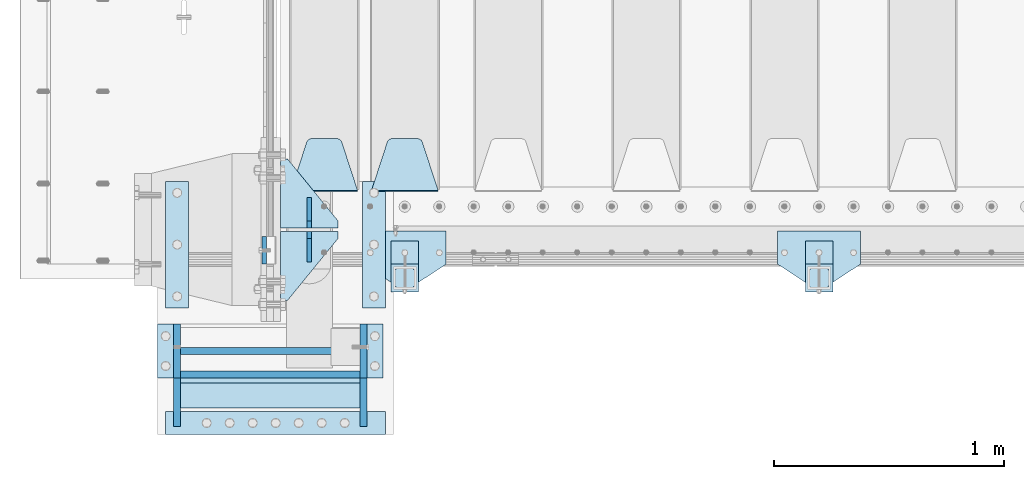
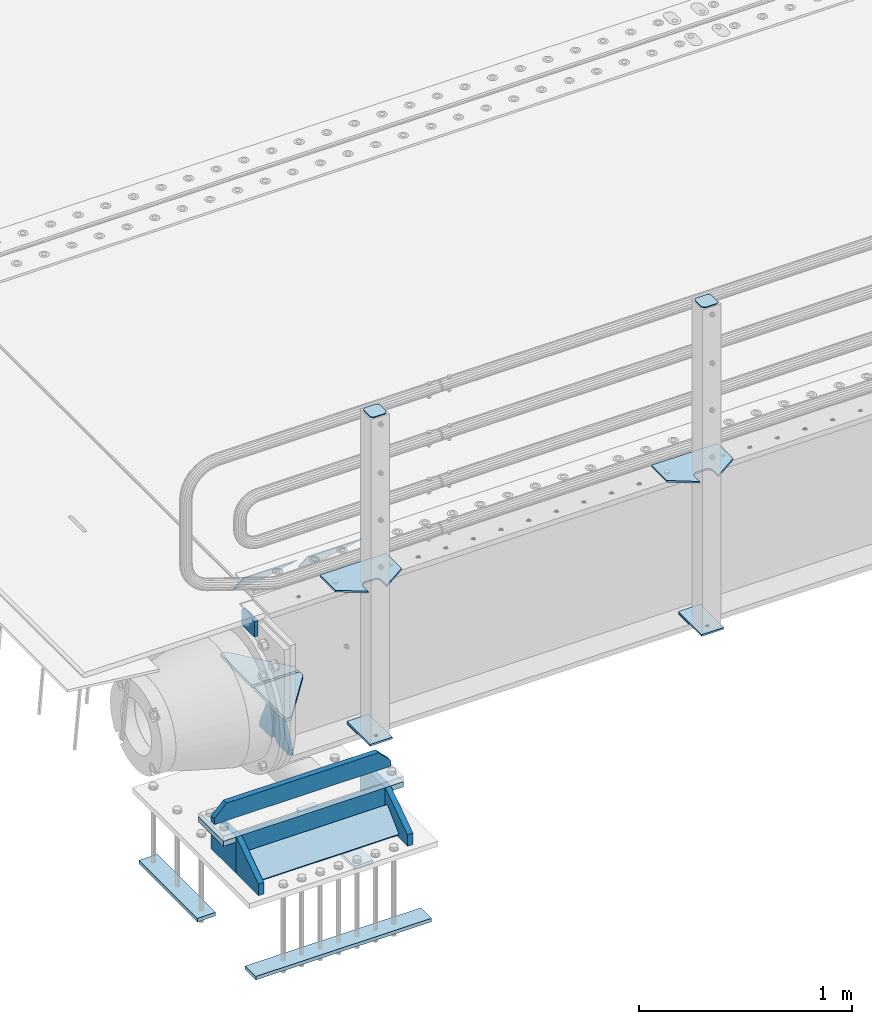
# One storey, part 190 of 240: 27 plates.
"""IFC2X3 building model written with IfcOpenShell, lengths in millimetres."""

from ifc_helpers import new_model, si_unit, frame, origin_with_axes, place, context, subcontext, project, spatial, faceted_brep, material, type_object, element, save


model = new_model("IFC2X3")

# Units and contexts
model_context = context("Model", 3, precision=1e-05, world=origin_with_axes())
body_context = subcontext(model_context, "Body", "Model", "MODEL_VIEW")
ifc_project = project(units=[si_unit("LENGTHUNIT", "METRE", prefix="MILLI"), si_unit("AREAUNIT", "SQUARE_METRE"), si_unit("VOLUMEUNIT", "CUBIC_METRE"), si_unit("MASSUNIT", "GRAM", prefix="KILO"), si_unit("TIMEUNIT", "SECOND"), si_unit("PLANEANGLEUNIT", "RADIAN"), si_unit("SOLIDANGLEUNIT", "STERADIAN"), si_unit("THERMODYNAMICTEMPERATUREUNIT", "DEGREE_CELSIUS"), si_unit("LUMINOUSINTENSITYUNIT", "LUMEN")], contexts=[model_context])

# Site, building, storey
site_placement = place(None, origin_with_axes())
site = spatial("IfcSite", under=ifc_project, at=site_placement, CompositionType="ELEMENT")
building_placement = place(site_placement, origin_with_axes())
building = spatial("IfcBuilding", under=site, at=building_placement, Name="Standard", CompositionType="ELEMENT")
storey_placement = place(building_placement, origin_with_axes())
storey = spatial("IfcBuildingStorey", under=building, at=storey_placement, Name="Undefined", CompositionType="ELEMENT", Elevation=0.0)

# Plates
ifc_material_1 = material(Name="STEEL/S355N")
plate_type_1 = type_object("IfcPlateType", PredefinedType="NOTDEFINED")
plate_1_placement = place(storey_placement, frame((42390.0, 23970.0004459814, -106.000123865875), z_axis=(0.0, -0.999999999987744, -4.95099999993769e-06), x_axis=(0.0, -4.95099997756316e-06, 0.999999999987744)))
element("IfcPlate", 1, at=plate_1_placement, inside=storey, type_object=plate_type_1, material=ifc_material_1, context=body_context, shape_type="Brep", body=[
    faceted_brep([(0.0, -10.0, 0.0), (5.70725632087488e-07, -10.0, 119.999999999993), (5.70725632087488e-07, 10.0, 119.999999999993), (0.0, 10.0, 0.0), (89.9999999999979, -10.0, 120.0), (89.9999999999979, 10.0, 120.0), (90.0, -10.0, 1.09139364212751e-11), (90.0, 10.0, 1.09139364212751e-11)], [[[0, 1, 2, 3]], [[1, 4, 5, 2]], [[4, 6, 7, 5]], [[6, 0, 3, 7]], [[5, 7, 3, 2]], [[6, 4, 1, 0]]]),
])
plate_type_2 = type_object("IfcPlateType", PredefinedType="NOTDEFINED")
plate_2_placement = place(storey_placement, frame((43145.0, 24168.232233047, -1.76776695296758), z_axis=(0.0, 0.707106781186547, -0.707106781186548), x_axis=(-1.0, 0.0, 0.0)))
element("IfcPlate", 2, at=plate_2_placement, inside=storey, type_object=plate_type_2, material=ifc_material_1, context=body_context, shape_type="Brep", body=[
    faceted_brep([(0.0, -2.5, 0.0), (69.345504679477, -2.50000000000364, 300.171731424827), (69.345504679477, 2.49999999999636, 300.171731424827), (0.0, 2.5, 0.0), (70.927406119954, -2.50000000000364, 304.897442415397), (70.927406119954, 2.49999999999636, 304.897442415397), (73.3818627772271, -2.50000000000728, 309.234538108525), (73.3818627772271, 2.49999999999636, 309.234538108529), (76.6187032999587, -2.50000000000728, 313.023683126099), (76.6187032999587, 2.49999999999636, 313.023683126103), (80.5190132705029, -2.50000000000364, 316.125672595368), (80.5190132705029, 2.49999999999636, 316.125672595368), (84.9395038596849, -2.50000000000364, 318.426546230472), (84.9395038596849, 2.49999999999636, 318.426546230472), (89.7177759439219, -2.5, 319.841774983277), (89.7177759439219, 2.49999999999636, 319.841774983273), (94.6782862926484, -2.50000000000364, 320.319366455074), (94.6782862926484, 2.49999999999636, 320.319366455074), (195.321713707352, -2.50000000000364, 320.319366455074), (195.321713707352, 2.49999999999636, 320.319366455074), (200.282224056078, -2.50000000000364, 319.841774983273), (200.282224056078, 2.49999999999636, 319.841774983273), (205.060496140315, -2.50000000000364, 318.426546230472), (205.060496140315, 2.49999999999636, 318.426546230472), (209.480986729497, -2.50000000000364, 316.125672595368), (209.480986729497, 2.49999999999636, 316.125672595368), (213.381296700041, -2.50000000000728, 313.023683126099), (213.381296700041, 2.49999999999272, 313.023683126099), (216.618137222766, -2.50000000000364, 309.234538108522), (216.618137222766, 2.49999999999636, 309.234538108522), (219.072593880039, -2.50000000000364, 304.897442415397), (219.072593880039, 2.49999999999636, 304.897442415397), (220.654495320523, -2.50000000000364, 300.171731424827), (220.654495320523, 2.49999999999636, 300.171731424827), (290.0, -2.50000000000364, -3.63797880709171e-12), (290.0, 2.49999999999636, -3.63797880709171e-12)], [[[0, 1, 2, 3]], [[1, 4, 5, 2]], [[4, 6, 7, 5]], [[6, 8, 9, 7]], [[8, 10, 11, 9]], [[10, 12, 13, 11]], [[12, 14, 15, 13]], [[14, 16, 17, 15]], [[16, 18, 19, 17]], [[18, 20, 21, 19]], [[20, 22, 23, 21]], [[22, 24, 25, 23]], [[24, 26, 27, 25]], [[26, 28, 29, 27]], [[28, 30, 31, 29]], [[30, 32, 33, 31]], [[32, 34, 35, 33]], [[34, 0, 3, 35]], [[5, 7, 9, 11, 13, 15, 17, 19, 21, 23, 25, 27, 29, 31, 33, 35, 3, 2]], [[34, 32, 30, 28, 26, 24, 22, 20, 18, 16, 14, 12, 10, 8, 6, 4, 1, 0]]]),
])
plate_3_placement = place(storey_placement, frame((42795.0, 24168.232233047, -1.76776695296758), z_axis=(0.0, 0.707106781186547, -0.707106781186548), x_axis=(-1.0, 0.0, 0.0)))
element("IfcPlate", 3, at=plate_3_placement, inside=storey, type_object=plate_type_2, material=ifc_material_1, context=body_context, shape_type="Brep", body=[
    faceted_brep([(0.0, -2.5, 0.0), (69.345504679477, -2.50000000000364, 300.171731424827), (69.345504679477, 2.49999999999636, 300.171731424827), (0.0, 2.5, 0.0), (70.927406119954, -2.50000000000364, 304.897442415397), (70.927406119954, 2.49999999999636, 304.897442415397), (73.3818627772271, -2.50000000000728, 309.234538108525), (73.3818627772271, 2.49999999999636, 309.234538108529), (76.6187032999587, -2.50000000000728, 313.023683126099), (76.6187032999587, 2.49999999999636, 313.023683126103), (80.5190132705029, -2.50000000000364, 316.125672595368), (80.5190132705029, 2.49999999999636, 316.125672595368), (84.9395038596849, -2.50000000000364, 318.426546230472), (84.9395038596849, 2.49999999999636, 318.426546230472), (89.7177759439219, -2.5, 319.841774983277), (89.7177759439219, 2.49999999999636, 319.841774983273), (94.6782862926484, -2.50000000000364, 320.319366455074), (94.6782862926484, 2.49999999999636, 320.319366455074), (195.321713707352, -2.50000000000364, 320.319366455074), (195.321713707352, 2.49999999999636, 320.319366455074), (200.282224056078, -2.50000000000364, 319.841774983273), (200.282224056078, 2.49999999999636, 319.841774983273), (205.060496140315, -2.50000000000364, 318.426546230472), (205.060496140315, 2.49999999999636, 318.426546230472), (209.480986729497, -2.50000000000364, 316.125672595368), (209.480986729497, 2.49999999999636, 316.125672595368), (213.381296700041, -2.50000000000728, 313.023683126099), (213.381296700041, 2.49999999999272, 313.023683126099), (216.618137222766, -2.50000000000364, 309.234538108522), (216.618137222766, 2.49999999999636, 309.234538108522), (219.072593880039, -2.50000000000364, 304.897442415397), (219.072593880039, 2.49999999999636, 304.897442415397), (220.654495320523, -2.50000000000364, 300.171731424827), (220.654495320523, 2.49999999999636, 300.171731424827), (290.0, -2.50000000000364, -3.63797880709171e-12), (290.0, 2.49999999999636, -3.63797880709171e-12)], [[[0, 1, 2, 3]], [[1, 4, 5, 2]], [[4, 6, 7, 5]], [[6, 8, 9, 7]], [[8, 10, 11, 9]], [[10, 12, 13, 11]], [[12, 14, 15, 13]], [[14, 16, 17, 15]], [[16, 18, 19, 17]], [[18, 20, 21, 19]], [[20, 22, 23, 21]], [[22, 24, 25, 23]], [[24, 26, 27, 25]], [[26, 28, 29, 27]], [[28, 30, 31, 29]], [[30, 32, 33, 31]], [[32, 34, 35, 33]], [[34, 0, 3, 35]], [[5, 7, 9, 11, 13, 15, 17, 19, 21, 23, 25, 27, 29, 31, 33, 35, 3, 2]], [[34, 32, 30, 28, 26, 24, 22, 20, 18, 16, 14, 12, 10, 8, 6, 4, 1, 0]]]),
])
plate_type_3 = type_object("IfcPlateType", PredefinedType="NOTDEFINED")
for number, where, z_axis, x_axis in (
    (4, (42710.0, 24008.0, -515.0), (0.0, 1.0, 0.0), (-1.0, 0.0, 0.0)),
    (5, (42710.0, 23992.0, -515.0), (0.0, -1.0, 0.0), (-1.0, 0.0, 0.0)),
):
    element("IfcPlate", number, at=place(storey_placement, frame(where, z_axis=z_axis, x_axis=x_axis)), inside=storey, type_object=plate_type_3, material=ifc_material_1, context=body_context, shape_type="Brep", body=[
        faceted_brep([(0.0, -10.0, 0.0), (0.0, -10.0, 30.0), (0.0, 10.0, 30.0), (0.0, 10.0, 0.0), (220.0, -10.0, 300.0), (220.0, 10.0, 300.0), (250.0, -10.0, 300.0), (250.0, 10.0, 300.0), (250.0, -10.0, 0.0), (250.0, 10.0, 0.0)], [[[0, 1, 2, 3]], [[1, 4, 5, 2]], [[4, 6, 7, 5]], [[6, 8, 9, 7]], [[8, 0, 3, 9]], [[5, 7, 9, 3, 2]], [[8, 6, 4, 1, 0]]]),
    ])
plate_type_4 = type_object("IfcPlateType", PredefinedType="NOTDEFINED")
for number, where, z_axis, x_axis in (
    (6, (42585.0, 23860.0, -860.0), (0.0, 0.0, 1.0), (0.0, 1.0, 0.0)),
    (7, (42585.0, 24140.0, -860.0), (0.0, 0.0, 1.0), (0.0, -1.0, 0.0)),
):
    element("IfcPlate", number, at=place(storey_placement, frame(where, z_axis=z_axis, x_axis=x_axis)), inside=storey, type_object=plate_type_4, material=ifc_material_1, context=body_context, shape_type="Brep", body=[
        faceted_brep([(0.0, -10.0, 0.0), (0.0, -10.0, 30.0), (0.0, 10.0, 30.0), (0.0, 10.0, 0.0), (102.0, -10.0, 250.0), (102.0, 10.0, 250.0), (132.0, -10.0, 250.0), (132.0, 10.0, 250.0), (132.0, -10.0, 30.0), (132.0, 10.0, 30.0), (131.544232590368, -10.0, 24.790554669992), (131.544232590368, 10.0, 24.790554669992), (130.190778623579, -10.0, 19.7393957002299), (130.190778623579, 10.0, 19.7393957002299), (127.980762113533, -10.0, 15.0), (127.980762113533, 10.0, 15.0), (124.98133329357, -10.0, 10.7163717094038), (124.98133329357, 10.0, 10.7163717094038), (121.283628290596, -10.0, 7.01866670643062), (121.283628290596, 10.0, 7.01866670643062), (117.0, -10.0, 4.01923788646684), (117.0, 10.0, 4.01923788646684), (112.260604299769, -10.0, 1.80922137642278), (112.260604299769, 10.0, 1.80922137642278), (107.209445330009, -10.0, 0.455767409633722), (107.209445330009, 10.0, 0.455767409633722), (102.0, -10.0, 0.0), (102.0, 10.0, 0.0)], [[[0, 1, 2, 3]], [[1, 4, 5, 2]], [[4, 6, 7, 5]], [[6, 8, 9, 7]], [[8, 10, 11, 9]], [[10, 12, 13, 11]], [[12, 14, 15, 13]], [[14, 16, 17, 15]], [[16, 18, 19, 17]], [[18, 20, 21, 19]], [[20, 22, 23, 21]], [[22, 24, 25, 23]], [[24, 26, 27, 25]], [[26, 0, 3, 27]], [[5, 7, 9, 11, 13, 15, 17, 19, 21, 23, 25, 27, 3, 2]], [[26, 24, 22, 20, 18, 16, 14, 12, 10, 8, 6, 4, 1, 0]]]),
    ])
ifc_material_2 = material(Name="STEEL/S355J2")
plate_type_5 = type_object("IfcPlateType", PredefinedType="NOTDEFINED")
plate_4_placement = place(storey_placement, frame((44980.0, 23995.0, 5.00000000004911), z_axis=(0.0, -1.0, 0.0), x_axis=(-1.0, 0.0, 0.0)))
element("IfcPlate", 8, at=plate_4_placement, inside=storey, type_object=plate_type_5, material=ifc_material_2, context=body_context, shape_type="Brep", body=[
    faceted_brep([(0.0, -5.0, 0.0), (2.31396552408114e-06, -5.0, 145.0), (2.31396552408114e-06, 5.0, 145.0), (0.0, 5.0, 0.0), (130.0, -5.0, 230.0), (130.0, 5.0, 230.0), (130.0, -5.0, 180.0), (130.0, 5.0, 180.0), (130.48036798992, -5.0, 175.122741949599), (130.48036798992, 5.0, 175.122741949599), (131.903011687216, -5.0, 170.432914190875), (131.903011687216, 5.0, 170.432914190875), (134.213259692435, -5.0, 166.110744174512), (134.213259692435, 5.0, 166.110744174512), (137.322330470335, -5.0, 162.322330470335), (137.322330470335, 5.0, 162.322330470335), (141.110744174512, -5.0, 159.213259692435), (141.110744174512, 5.0, 159.213259692435), (145.432914190875, -5.0, 156.903011687216), (145.432914190875, 5.0, 156.903011687216), (150.122741949599, -5.0, 155.48036798992), (150.122741949599, 5.0, 155.48036798992), (155.0, -5.0, 155.0), (155.0, 5.0, 155.0), (205.0, -5.0, 155.0), (205.0, 5.0, 155.0), (209.877258050401, -5.0, 155.48036798992), (209.877258050401, 5.0, 155.48036798992), (214.567085809125, -5.0, 156.903011687216), (214.567085809125, 5.0, 156.903011687216), (218.889255825488, -5.0, 159.213259692435), (218.889255825488, 5.0, 159.213259692435), (222.677669529665, -5.0, 162.322330470335), (222.677669529665, 5.0, 162.322330470335), (225.786740307565, -5.0, 166.110744174512), (225.786740307565, 5.0, 166.110744174512), (228.096988312784, -5.0, 170.432914190875), (228.096988312784, 5.0, 170.432914190875), (229.51963201008, -5.0, 175.122741949599), (229.51963201008, 5.0, 175.122741949599), (230.0, -5.0, 180.0), (230.0, 5.0, 180.0), (230.0, -5.0, 230.0), (230.0, 5.0, 230.0), (360.0, -5.0, 145.0), (360.0, 5.0, 145.0), (360.0, -5.0, -7.27595761418343e-12), (360.0, 5.0, -7.27595761418343e-12)], [[[0, 1, 2, 3]], [[1, 4, 5, 2]], [[4, 6, 7, 5]], [[6, 8, 9, 7]], [[8, 10, 11, 9]], [[10, 12, 13, 11]], [[12, 14, 15, 13]], [[14, 16, 17, 15]], [[16, 18, 19, 17]], [[18, 20, 21, 19]], [[20, 22, 23, 21]], [[22, 24, 25, 23]], [[24, 26, 27, 25]], [[26, 28, 29, 27]], [[28, 30, 31, 29]], [[30, 32, 33, 31]], [[32, 34, 35, 33]], [[34, 36, 37, 35]], [[36, 38, 39, 37]], [[38, 40, 41, 39]], [[40, 42, 43, 41]], [[42, 44, 45, 43]], [[44, 46, 47, 45]], [[46, 0, 3, 47]], [[5, 7, 9, 11, 13, 15, 17, 19, 21, 23, 25, 27, 29, 31, 33, 35, 37, 39, 41, 43, 45, 47, 3, 2]], [[46, 44, 42, 40, 38, 36, 34, 32, 30, 28, 26, 24, 22, 20, 18, 16, 14, 12, 10, 8, 6, 4, 1, 0]]]),
])
plate_5_placement = place(storey_placement, frame((43180.0, 23995.0, 5.00000000004911), z_axis=(0.0, -1.0, 0.0), x_axis=(-1.0, 0.0, 0.0)))
element("IfcPlate", 9, at=plate_5_placement, inside=storey, type_object=plate_type_5, material=ifc_material_2, context=body_context, shape_type="Brep", body=[
    faceted_brep([(0.0, -5.0, 0.0), (2.31396552408114e-06, -5.0, 145.0), (2.31396552408114e-06, 5.0, 145.0), (0.0, 5.0, 0.0), (130.0, -5.0, 230.0), (130.0, 5.0, 230.0), (130.0, -5.0, 180.0), (130.0, 5.0, 180.0), (130.48036798992, -5.0, 175.122741949599), (130.48036798992, 5.0, 175.122741949599), (131.903011687216, -5.0, 170.432914190875), (131.903011687216, 5.0, 170.432914190875), (134.213259692435, -5.0, 166.110744174512), (134.213259692435, 5.0, 166.110744174512), (137.322330470335, -5.0, 162.322330470335), (137.322330470335, 5.0, 162.322330470335), (141.110744174512, -5.0, 159.213259692435), (141.110744174512, 5.0, 159.213259692435), (145.432914190875, -5.0, 156.903011687216), (145.432914190875, 5.0, 156.903011687216), (150.122741949599, -5.0, 155.48036798992), (150.122741949599, 5.0, 155.48036798992), (155.0, -5.0, 155.0), (155.0, 5.0, 155.0), (205.0, -5.0, 155.0), (205.0, 5.0, 155.0), (209.877258050401, -5.0, 155.48036798992), (209.877258050401, 5.0, 155.48036798992), (214.567085809125, -5.0, 156.903011687216), (214.567085809125, 5.0, 156.903011687216), (218.889255825488, -5.0, 159.213259692435), (218.889255825488, 5.0, 159.213259692435), (222.677669529665, -5.0, 162.322330470335), (222.677669529665, 5.0, 162.322330470335), (225.786740307565, -5.0, 166.110744174512), (225.786740307565, 5.0, 166.110744174512), (228.096988312784, -5.0, 170.432914190875), (228.096988312784, 5.0, 170.432914190875), (229.51963201008, -5.0, 175.122741949599), (229.51963201008, 5.0, 175.122741949599), (230.0, -5.0, 180.0), (230.0, 5.0, 180.0), (230.0, -5.0, 230.0), (230.0, 5.0, 230.0), (360.0, -5.0, 145.0), (360.0, 5.0, 145.0), (360.0, -5.0, -7.27595761418343e-12), (360.0, 5.0, -7.27595761418343e-12)], [[[0, 1, 2, 3]], [[1, 4, 5, 2]], [[4, 6, 7, 5]], [[6, 8, 9, 7]], [[8, 10, 11, 9]], [[10, 12, 13, 11]], [[12, 14, 15, 13]], [[14, 16, 17, 15]], [[16, 18, 19, 17]], [[18, 20, 21, 19]], [[20, 22, 23, 21]], [[22, 24, 25, 23]], [[24, 26, 27, 25]], [[26, 28, 29, 27]], [[28, 30, 31, 29]], [[30, 32, 33, 31]], [[32, 34, 35, 33]], [[34, 36, 37, 35]], [[36, 38, 39, 37]], [[38, 40, 41, 39]], [[40, 42, 43, 41]], [[42, 44, 45, 43]], [[44, 46, 47, 45]], [[46, 0, 3, 47]], [[5, 7, 9, 11, 13, 15, 17, 19, 21, 23, 25, 27, 29, 31, 33, 35, 37, 39, 41, 43, 45, 47, 3, 2]], [[46, 44, 42, 40, 38, 36, 34, 32, 30, 28, 26, 24, 22, 20, 18, 16, 14, 12, 10, 8, 6, 4, 1, 0]]]),
])
plate_type_6 = type_object("IfcPlateType", PredefinedType="NOTDEFINED")
for number, where, z_axis, x_axis in (
    (10, (44859.9999999999, 23949.9999999998, -850.000000000002), (0.0, -1.0, 0.0), (-1.0, 0.0, 0.0)),
    (11, (43059.9999999999, 23949.9999999998, -850.000000000002), (0.0, -1.0, 0.0), (-1.0, 0.0, 0.0)),
):
    element("IfcPlate", number, at=place(storey_placement, frame(where, z_axis=z_axis, x_axis=x_axis)), inside=storey, type_object=plate_type_6, material=ifc_material_2, context=body_context, shape_type="Brep", body=[
        faceted_brep([(53.6360389691836, -5.0, 176.363961030467), (53.6360389691836, 5.0, 176.363961030467), (59.9999999998618, 5.0, 178.999999999789), (59.9999999998618, -5.0, 178.999999999789), (66.3639610305399, 5.0, 176.363961030467), (66.3639610305399, -5.0, 176.363961030467), (68.9999999998618, 5.0, 169.999999999789), (68.9999999998618, -5.0, 169.999999999789), (66.3639610305399, 5.0, 163.636038969111), (66.3639610305399, -5.0, 163.636038969111), (59.9999999998618, 5.0, 160.999999999789), (59.9999999998618, -5.0, 160.999999999789), (53.6360389691836, 5.0, 163.636038969111), (53.6360389691836, -5.0, 163.636038969111), (50.9999999998618, 5.0, 169.999999999789), (50.9999999998618, -5.0, 169.999999999789), (120.0, -5.0, 0.0), (120.0, -5.0, 220.0), (0.0, -5.0, 220.0), (0.0, -5.0, 0.0), (0.0, 5.0, 0.0), (120.0, 5.0, 0.0), (120.0, 5.0, 220.0), (0.0, 5.0, 220.0)], [[[0, 1, 2, 3]], [[3, 2, 4, 5]], [[5, 4, 6, 7]], [[7, 6, 8, 9]], [[9, 8, 10, 11]], [[11, 10, 12, 13]], [[13, 12, 14, 15]], [[15, 14, 1, 0]], [[16, 17, 18, 19], [11, 13, 15, 0, 3, 5, 7, 9]], [[16, 19, 20, 21]], [[17, 16, 21, 22]], [[18, 17, 22, 23]], [[19, 18, 23, 20]], [[22, 21, 20, 23], [2, 1, 14, 12, 10, 8, 6, 4]]]),
    ])
plate_type_7 = type_object("IfcPlateType", PredefinedType="NOTDEFINED")
plate_6_placement = place(storey_placement, frame((44755.9999999999, 23833.9999999998, 1012.50000000001), z_axis=(0.0, -1.0, 0.0), x_axis=(1.0, 0.0, 0.0)))
element("IfcPlate", 12, at=plate_6_placement, inside=storey, type_object=plate_type_7, material=ifc_material_2, context=body_context, shape_type="Brep", body=[
    faceted_brep([(0.0, -2.5, 19.0), (0.0, -2.5, 69.0), (0.0, 2.5, 69.0), (0.0, 2.5, 19.0), (0.476369668547704, -2.5, 73.2278977451715), (0.476369668547704, 2.5, 73.2278977451715), (1.88159150985302, -2.5, 77.2437910432345), (1.88159150985302, 2.5, 77.2437910432345), (4.14520183311106, -2.5, 80.8463062353185), (4.14520183311106, 2.5, 80.8463062353185), (7.15369376468152, -2.5, 83.8547981668889), (7.15369376468152, 2.5, 83.8547981668889), (10.7562089567655, -2.5, 86.118408490147), (10.7562089567655, 2.5, 86.118408490147), (14.7721022548285, -2.5, 87.5236303314523), (14.7721022548285, 2.5, 87.5236303314523), (19.0, -2.5, 88.0), (19.0, 2.5, 88.0), (69.0, -2.5, 88.0), (69.0, 2.5, 88.0), (73.2278977451715, -2.5, 87.5236303314523), (73.2278977451715, 2.5, 87.5236303314523), (77.2437910432345, -2.5, 86.118408490147), (77.2437910432345, 2.5, 86.118408490147), (80.8463062353185, -2.5, 83.8547981668889), (80.8463062353185, 2.5, 83.8547981668889), (83.8547981668889, -2.5, 80.8463062353185), (83.8547981668889, 2.5, 80.8463062353185), (86.118408490147, -2.5, 77.2437910432345), (86.118408490147, 2.5, 77.2437910432345), (87.5236303314523, -2.5, 73.2278977451715), (87.5236303314523, 2.5, 73.2278977451715), (88.0, -2.5, 69.0), (88.0, 2.5, 69.0), (88.0, -2.5, 19.0), (88.0, 2.5, 19.0), (87.5236303314523, -2.5, 14.7721022548285), (87.5236303314523, 2.5, 14.7721022548285), (86.118408490147, -2.5, 10.7562089567655), (86.118408490147, 2.5, 10.7562089567655), (83.8547981668889, -2.5, 7.15369376468152), (83.8547981668889, 2.5, 7.15369376468152), (80.8463062353185, -2.5, 4.14520183311106), (80.8463062353185, 2.5, 4.14520183311106), (77.2437910432345, -2.5, 1.88159150985302), (77.2437910432345, 2.5, 1.88159150985302), (73.2278977451715, -2.5, 0.476369668547704), (73.2278977451715, 2.5, 0.476369668547704), (69.0, -2.5, 0.0), (69.0, 2.5, 0.0), (19.0, -2.5, 0.0), (19.0, 2.5, 0.0), (14.7721022548285, -2.5, 0.476369668547704), (14.7721022548285, 2.5, 0.476369668547704), (10.7562089567655, -2.5, 1.88159150985302), (10.7562089567655, 2.5, 1.88159150985302), (7.15369376468152, -2.5, 4.14520183311106), (7.15369376468152, 2.5, 4.14520183311106), (4.14520183311106, -2.5, 7.15369376468152), (4.14520183311106, 2.5, 7.15369376468152), (1.88159150985302, -2.5, 10.7562089567655), (1.88159150985302, 2.5, 10.7562089567655), (0.476369668547704, -2.5, 14.7721022548285), (0.476369668547704, 2.5, 14.7721022548285)], [[[0, 1, 2, 3]], [[1, 4, 5, 2]], [[4, 6, 7, 5]], [[6, 8, 9, 7]], [[8, 10, 11, 9]], [[10, 12, 13, 11]], [[12, 14, 15, 13]], [[14, 16, 17, 15]], [[16, 18, 19, 17]], [[18, 20, 21, 19]], [[20, 22, 23, 21]], [[22, 24, 25, 23]], [[24, 26, 27, 25]], [[26, 28, 29, 27]], [[28, 30, 31, 29]], [[30, 32, 33, 31]], [[32, 34, 35, 33]], [[34, 36, 37, 35]], [[36, 38, 39, 37]], [[38, 40, 41, 39]], [[40, 42, 43, 41]], [[42, 44, 45, 43]], [[44, 46, 47, 45]], [[46, 48, 49, 47]], [[48, 50, 51, 49]], [[50, 52, 53, 51]], [[52, 54, 55, 53]], [[54, 56, 57, 55]], [[56, 58, 59, 57]], [[58, 60, 61, 59]], [[60, 62, 63, 61]], [[62, 0, 3, 63]], [[5, 7, 9, 11, 13, 15, 17, 19, 21, 23, 25, 27, 29, 31, 33, 35, 37, 39, 41, 43, 45, 47, 49, 51, 53, 55, 57, 59, 61, 63, 3, 2]], [[62, 60, 58, 56, 54, 52, 50, 48, 46, 44, 42, 40, 38, 36, 34, 32, 30, 28, 26, 24, 22, 20, 18, 16, 14, 12, 10, 8, 6, 4, 1, 0]]]),
])
plate_7_placement = place(storey_placement, frame((42955.9999999999, 23833.9999999998, 1012.50000000001), z_axis=(0.0, -1.0, 0.0), x_axis=(1.0, 0.0, 0.0)))
element("IfcPlate", 13, at=plate_7_placement, inside=storey, type_object=plate_type_7, material=ifc_material_2, context=body_context, shape_type="Brep", body=[
    faceted_brep([(0.0, -2.5, 19.0), (0.0, -2.5, 69.0), (0.0, 2.5, 69.0), (0.0, 2.5, 19.0), (0.476369668547704, -2.5, 73.2278977451715), (0.476369668547704, 2.5, 73.2278977451715), (1.88159150985302, -2.5, 77.2437910432345), (1.88159150985302, 2.5, 77.2437910432345), (4.14520183311106, -2.5, 80.8463062353185), (4.14520183311106, 2.5, 80.8463062353185), (7.15369376468152, -2.5, 83.8547981668889), (7.15369376468152, 2.5, 83.8547981668889), (10.7562089567655, -2.5, 86.118408490147), (10.7562089567655, 2.5, 86.118408490147), (14.7721022548285, -2.5, 87.5236303314523), (14.7721022548285, 2.5, 87.5236303314523), (19.0, -2.5, 88.0), (19.0, 2.5, 88.0), (69.0, -2.5, 88.0), (69.0, 2.5, 88.0), (73.2278977451715, -2.5, 87.5236303314523), (73.2278977451715, 2.5, 87.5236303314523), (77.2437910432345, -2.5, 86.118408490147), (77.2437910432345, 2.5, 86.118408490147), (80.8463062353185, -2.5, 83.8547981668889), (80.8463062353185, 2.5, 83.8547981668889), (83.8547981668889, -2.5, 80.8463062353185), (83.8547981668889, 2.5, 80.8463062353185), (86.118408490147, -2.5, 77.2437910432345), (86.118408490147, 2.5, 77.2437910432345), (87.5236303314523, -2.5, 73.2278977451715), (87.5236303314523, 2.5, 73.2278977451715), (88.0, -2.5, 69.0), (88.0, 2.5, 69.0), (88.0, -2.5, 19.0), (88.0, 2.5, 19.0), (87.5236303314523, -2.5, 14.7721022548285), (87.5236303314523, 2.5, 14.7721022548285), (86.118408490147, -2.5, 10.7562089567655), (86.118408490147, 2.5, 10.7562089567655), (83.8547981668889, -2.5, 7.15369376468152), (83.8547981668889, 2.5, 7.15369376468152), (80.8463062353185, -2.5, 4.14520183311106), (80.8463062353185, 2.5, 4.14520183311106), (77.2437910432345, -2.5, 1.88159150985302), (77.2437910432345, 2.5, 1.88159150985302), (73.2278977451715, -2.5, 0.476369668547704), (73.2278977451715, 2.5, 0.476369668547704), (69.0, -2.5, 0.0), (69.0, 2.5, 0.0), (19.0, -2.5, 0.0), (19.0, 2.5, 0.0), (14.7721022548285, -2.5, 0.476369668547704), (14.7721022548285, 2.5, 0.476369668547704), (10.7562089567655, -2.5, 1.88159150985302), (10.7562089567655, 2.5, 1.88159150985302), (7.15369376468152, -2.5, 4.14520183311106), (7.15369376468152, 2.5, 4.14520183311106), (4.14520183311106, -2.5, 7.15369376468152), (4.14520183311106, 2.5, 7.15369376468152), (1.88159150985302, -2.5, 10.7562089567655), (1.88159150985302, 2.5, 10.7562089567655), (0.476369668547704, -2.5, 14.7721022548285), (0.476369668547704, 2.5, 14.7721022548285)], [[[0, 1, 2, 3]], [[1, 4, 5, 2]], [[4, 6, 7, 5]], [[6, 8, 9, 7]], [[8, 10, 11, 9]], [[10, 12, 13, 11]], [[12, 14, 15, 13]], [[14, 16, 17, 15]], [[16, 18, 19, 17]], [[18, 20, 21, 19]], [[20, 22, 23, 21]], [[22, 24, 25, 23]], [[24, 26, 27, 25]], [[26, 28, 29, 27]], [[28, 30, 31, 29]], [[30, 32, 33, 31]], [[32, 34, 35, 33]], [[34, 36, 37, 35]], [[36, 38, 39, 37]], [[38, 40, 41, 39]], [[40, 42, 43, 41]], [[42, 44, 45, 43]], [[44, 46, 47, 45]], [[46, 48, 49, 47]], [[48, 50, 51, 49]], [[50, 52, 53, 51]], [[52, 54, 55, 53]], [[54, 56, 57, 55]], [[56, 58, 59, 57]], [[58, 60, 61, 59]], [[60, 62, 63, 61]], [[62, 0, 3, 63]], [[5, 7, 9, 11, 13, 15, 17, 19, 21, 23, 25, 27, 29, 31, 33, 35, 37, 39, 41, 43, 45, 47, 49, 51, 53, 55, 57, 59, 61, 63, 3, 2]], [[62, 60, 58, 56, 54, 52, 50, 48, 46, 44, 42, 40, 38, 36, 34, 32, 30, 28, 26, 24, 22, 20, 18, 16, 14, 12, 10, 8, 6, 4, 1, 0]]]),
])
plate_type_8 = type_object("IfcPlateType", PredefinedType="NOTDEFINED")
for number, where, z_axis, x_axis in (
    (14, (44859.9999999999, 23949.9999999998, -857.500000000002), (0.0, -1.0, 0.0), (-1.0, 0.0, 0.0)),
    (15, (43059.9999999999, 23949.9999999998, -857.500000000002), (0.0, -1.0, 0.0), (-1.0, 0.0, 0.0)),
):
    element("IfcPlate", number, at=place(storey_placement, frame(where, z_axis=z_axis, x_axis=x_axis)), inside=storey, type_object=plate_type_8, material=ifc_material_2, context=body_context, shape_type="Brep", body=[
        faceted_brep([(0.0, -2.5, 0.0), (0.0, -2.5, 100.0), (0.0, 2.5, 100.0), (0.0, 2.5, 0.0), (120.0, -2.5, 100.0), (120.0, 2.5, 100.0), (120.0, -2.5, 0.0), (120.0, 2.5, 0.0)], [[[0, 1, 2, 3]], [[1, 4, 5, 2]], [[4, 6, 7, 5]], [[6, 0, 3, 7]], [[5, 7, 3, 2]], [[6, 4, 1, 0]]]),
    ])
plate_type_9 = type_object("IfcPlateType", PredefinedType="NOTDEFINED")
plate_8_placement = place(storey_placement, frame((42805.0, 23234.6428652468, -1017.14966545662), z_axis=(-1.0, 0.0, 0.0), x_axis=(0.0, 0.723355636225727, 0.690475650215469)))
element("IfcPlate", 16, at=plate_8_placement, inside=storey, type_object=plate_type_9, material=ifc_material_1, context=body_context, shape_type="Brep", body=[
    faceted_brep([(0.0, -15.0, 0.0), (0.0, -14.9999999999964, 779.0), (-3.63797880709171e-12, 15.0000000000036, 779.0), (0.0, 15.0, 0.0), (152.069061279293, -14.9999999999964, 779.0), (152.069061279297, 15.0000000000036, 779.0), (152.069061279293, -14.9999999999964, 0.0), (152.069061279297, 15.0000000000036, 0.0)], [[[0, 1, 2, 3]], [[1, 4, 5, 2]], [[4, 6, 7, 5]], [[6, 0, 3, 7]], [[5, 7, 3, 2]], [[6, 4, 1, 0]]]),
])
plate_type_10 = type_object("IfcPlateType", PredefinedType="NOTDEFINED")
for number, where, z_axis, x_axis in (
    (17, (42816.0, 23660.0000014662, -1468.0), (0.0, 1.0, 0.0), (1.0, 0.0, 0.0)),
    (18, (41961.0, 23660.0000014662, -1468.0), (0.0, 1.0, 0.0), (1.0, 0.0, 0.0)),
):
    element("IfcPlate", number, at=place(storey_placement, frame(where, z_axis=z_axis, x_axis=x_axis)), inside=storey, type_object=plate_type_10, material=ifc_material_1, context=body_context, shape_type="Brep", body=[
        faceted_brep([(0.0, -10.0, 0.0), (1.00942997960374e-06, -10.0, 550.0), (1.00942997960374e-06, 10.0, 550.0), (0.0, 10.0, 0.0), (100.0, -10.0, 550.0), (100.0, 10.0, 550.0), (100.0, -10.0, 0.0), (100.0, 10.0, 0.0)], [[[0, 1, 2, 3]], [[1, 4, 5, 2]], [[4, 6, 7, 5]], [[6, 0, 3, 7]], [[5, 7, 3, 2]], [[6, 4, 1, 0]]]),
    ])
plate_9_placement = place(storey_placement, frame((41961.0, 23110.0000014662, -1468.0), z_axis=(0.0, 1.0, 0.0), x_axis=(1.0, 0.0, 0.0)))
element("IfcPlate", 19, at=plate_9_placement, inside=storey, type_object=plate_type_10, material=ifc_material_1, context=body_context, shape_type="Brep", body=[
    faceted_brep([(0.0, -10.0, 0.0), (0.0, -10.0, 100.0), (0.0, 10.0, 100.0), (0.0, 10.0, 0.0), (955.0, -10.0, 100.0), (955.0, 10.0, 100.0), (955.0, -10.0, 0.0), (955.0, 10.0, 0.0)], [[[0, 1, 2, 3]], [[1, 4, 5, 2]], [[4, 6, 7, 5]], [[6, 0, 3, 7]], [[5, 7, 3, 2]], [[6, 4, 1, 0]]]),
])
plate_type_11 = type_object("IfcPlateType", PredefinedType="NOTDEFINED")
plate_10_placement = place(storey_placement, frame((42820.0, 23590.0, -818.000000000005), z_axis=(0.0, 0.0, -1.0), x_axis=(0.0, -1.0, 0.0)))
element("IfcPlate", 20, at=plate_10_placement, inside=storey, type_object=plate_type_11, material=ifc_material_1, context=body_context, shape_type="Brep", body=[
    faceted_brep([(0.0, -15.0, 0.0), (0.0, -15.0, 210.0), (0.0, 15.0, 210.0), (0.0, 15.0, 0.0), (235.0, -15.0, 210.0), (235.0, 15.0, 210.0), (235.0, -15.0, 0.0), (235.0, 15.0, 0.0)], [[[0, 1, 2, 3]], [[1, 4, 5, 2]], [[4, 6, 7, 5]], [[6, 0, 3, 7]], [[5, 7, 3, 2]], [[6, 4, 1, 0]]]),
])
for number, where, z_axis, x_axis in (
    (21, (42820.0, 23145.0, -1028.0), (0.0, 0.0, 1.0), (0.0, 1.0, 0.0)),
    (22, (42011.0, 23145.0, -1028.0), (0.0, 0.0, 1.0), (0.0, 1.0, 0.0)),
):
    element("IfcPlate", number, at=place(storey_placement, frame(where, z_axis=z_axis, x_axis=x_axis)), inside=storey, type_object=plate_type_11, material=ifc_material_1, context=body_context, shape_type="Brep", body=[
        faceted_brep([(0.0, -15.0, 0.0), (0.0, -15.0, 66.0), (0.0, 15.0, 66.0), (0.0, 15.0, 0.0), (210.0, -15.0, 210.0), (210.0, 15.0, 210.0), (210.0, -15.0, 0.0), (210.0, 15.0, 0.0)], [[[0, 1, 2, 3]], [[1, 4, 5, 2]], [[4, 6, 7, 5]], [[6, 0, 3, 7]], [[5, 7, 3, 2]], [[6, 4, 1, 0]]]),
    ])
plate_11_placement = place(storey_placement, frame((42026.0, 23370.0, -1028.0), z_axis=(1.0, 0.0, 0.0), x_axis=(0.0, 0.0, 1.0)))
element("IfcPlate", 23, at=plate_11_placement, inside=storey, type_object=plate_type_11, material=ifc_material_1, context=body_context, shape_type="Brep", body=[
    faceted_brep([(0.0, -15.0, 0.0), (0.0, -14.9999999999964, 779.0), (-3.63797880709171e-12, 15.0000000000036, 779.0), (0.0, 15.0, 0.0), (210.0, -15.0, 779.0), (210.0, 15.0, 779.0), (210.0, -15.0, 0.0), (210.0, 15.0, 0.0)], [[[0, 1, 2, 3]], [[1, 4, 5, 2]], [[4, 6, 7, 5]], [[6, 0, 3, 7]], [[5, 7, 3, 2]], [[6, 4, 1, 0]]]),
])
plate_12_placement = place(storey_placement, frame((42011.0, 23590.0, -818.000000000004), z_axis=(0.0, 0.0, -1.0), x_axis=(0.0, -1.0, 0.0)))
element("IfcPlate", 24, at=plate_12_placement, inside=storey, type_object=plate_type_11, material=ifc_material_1, context=body_context, shape_type="Brep", body=[
    faceted_brep([(0.0, -15.0, 0.0), (0.0, -15.0, 210.0), (0.0, 15.0, 210.0), (0.0, 15.0, 0.0), (235.0, -15.0, 210.0), (235.0, 15.0, 210.0), (235.0, -15.0, 0.0), (235.0, 15.0, 0.0)], [[[0, 1, 2, 3]], [[1, 4, 5, 2]], [[4, 6, 7, 5]], [[6, 0, 3, 7]], [[5, 7, 3, 2]], [[6, 4, 1, 0]]]),
])
plate_type_12 = type_object("IfcPlateType", PredefinedType="NOTDEFINED")
plate_13_placement = place(storey_placement, frame((41936.0, 23472.5, -788.000000000004), z_axis=(0.0, 0.0, 1.0), x_axis=(1.0, 0.0, 0.0)))
element("IfcPlate", 25, at=plate_13_placement, inside=storey, type_object=plate_type_12, material=ifc_material_1, context=body_context, shape_type="Brep", body=[
    faceted_brep([(0.0, -15.0, 0.0), (0.0, -15.0, 33.0), (0.0, 15.0, 33.0), (0.0, 15.0, 0.0), (67.0, -15.0, 100.0), (67.0, 15.0, 100.0), (892.0, -15.0, 100.0), (892.0, 15.0, 100.0), (959.0, -15.0, 33.0), (959.0, 15.0, 33.0), (959.0, -15.0, 0.0), (959.0, 15.0, 0.0)], [[[0, 1, 2, 3]], [[1, 4, 5, 2]], [[4, 6, 7, 5]], [[6, 8, 9, 7]], [[8, 10, 11, 9]], [[10, 0, 3, 11]], [[5, 7, 9, 11, 3, 2]], [[10, 8, 6, 4, 1, 0]]]),
])
plate_type_13 = type_object("IfcPlateType", PredefinedType="NOTDEFINED")
for number, where, z_axis, x_axis in (
    (26, (42835.0, 23355.0, -833.000000000004), (1.0, 0.0, 0.0), (0.0, 1.0, 0.0)),
    (27, (41926.0, 23355.0, -833.000000000004), (1.0, 0.0, 0.0), (0.0, 1.0, 0.0)),
):
    element("IfcPlate", number, at=place(storey_placement, frame(where, z_axis=z_axis, x_axis=x_axis)), inside=storey, type_object=plate_type_13, material=ifc_material_1, context=body_context, shape_type="Brep", body=[
        faceted_brep([(0.0, -15.0, 0.0), (0.0, -15.0, 70.0), (0.0, 15.0, 70.0), (0.0, 15.0, 0.0), (235.0, -15.0, 70.0), (235.0, 15.0, 70.0), (235.0, -15.0, 0.0), (235.0, 15.0, 0.0)], [[[0, 1, 2, 3]], [[1, 4, 5, 2]], [[4, 6, 7, 5]], [[6, 0, 3, 7]], [[5, 7, 3, 2]], [[6, 4, 1, 0]]]),
    ])

save(model, "model.ifc")
